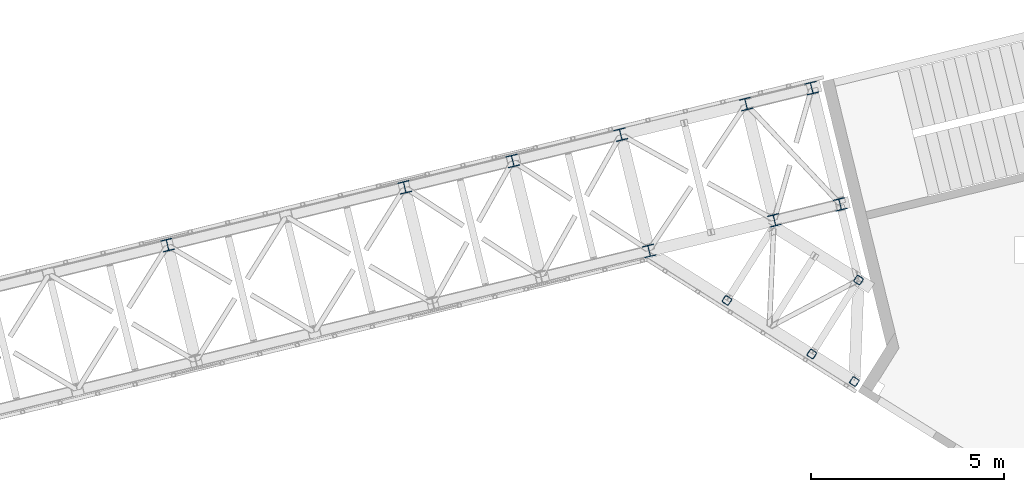
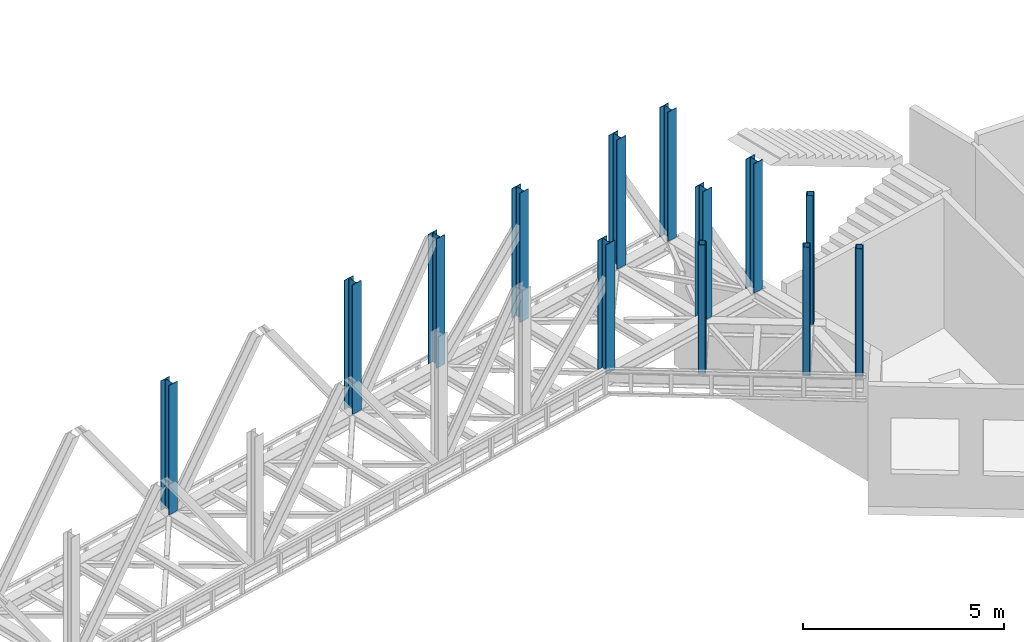
# One storey, part 3 of 92: 13 columns.
"""IFC4 building model written with IfcOpenShell, lengths in millimetres."""

from ifc_helpers import new_model, entity, si_unit, converted_unit, derived_unit, direction, frame, origin, place, context, subcontext, project, spatial, indexed_curve, outline, extrude, type_object, element, save


model = new_model("IFC4")

# Units and contexts
model_context = context("Model", 3, precision=0.01, world=origin(), true_north=direction((6.12303176911189e-17, 1.0)))
plan_context = context("Plan", 3, precision=0.01, world=origin(), true_north=direction((6.12303176911189e-17, 1.0)))
body_context = subcontext(model_context, "Body", "Model", "MODEL_VIEW")
ifc_project = project(units=[si_unit("LENGTHUNIT", "METRE", prefix="MILLI"), si_unit("AREAUNIT", "SQUARE_METRE"), si_unit("VOLUMEUNIT", "CUBIC_METRE"), converted_unit("PLANEANGLEUNIT", "DEGREE", entity("IfcRatioMeasure", 0.0174532925199433), si_unit("PLANEANGLEUNIT", "RADIAN"), dimensions=[0, 0, 0, 0, 0, 0, 0]), si_unit("MASSUNIT", "GRAM", prefix="KILO"), derived_unit("MASSDENSITYUNIT", [(si_unit("MASSUNIT", "GRAM", prefix="KILO"), 1), (si_unit("LENGTHUNIT", "METRE"), -3)]), derived_unit("MOMENTOFINERTIAUNIT", [(si_unit("LENGTHUNIT", "METRE"), 4)]), si_unit("TIMEUNIT", "SECOND"), si_unit("FREQUENCYUNIT", "HERTZ"), si_unit("THERMODYNAMICTEMPERATUREUNIT", "DEGREE_CELSIUS"), derived_unit("THERMALTRANSMITTANCEUNIT", [(si_unit("MASSUNIT", "GRAM", prefix="KILO"), 1), (si_unit("THERMODYNAMICTEMPERATUREUNIT", "KELVIN"), -1), (si_unit("TIMEUNIT", "SECOND"), -3)]), derived_unit("VOLUMETRICFLOWRATEUNIT", [(si_unit("LENGTHUNIT", "METRE"), 3), (si_unit("TIMEUNIT", "SECOND"), -1)]), derived_unit("MASSFLOWRATEUNIT", [(si_unit("MASSUNIT", "GRAM", prefix="KILO"), 1), (si_unit("TIMEUNIT", "SECOND"), -1)]), derived_unit("ROTATIONALFREQUENCYUNIT", [(si_unit("TIMEUNIT", "SECOND"), -1)]), si_unit("ELECTRICCURRENTUNIT", "AMPERE"), si_unit("ELECTRICVOLTAGEUNIT", "VOLT"), si_unit("POWERUNIT", "WATT"), si_unit("FORCEUNIT", "NEWTON", prefix="KILO"), si_unit("ILLUMINANCEUNIT", "LUX"), si_unit("LUMINOUSFLUXUNIT", "LUMEN"), si_unit("LUMINOUSINTENSITYUNIT", "CANDELA"), derived_unit("USERDEFINED", [(si_unit("MASSUNIT", "GRAM", prefix="KILO"), -1), (si_unit("LENGTHUNIT", "METRE"), -2), (si_unit("TIMEUNIT", "SECOND"), 3), (si_unit("LUMINOUSFLUXUNIT", "LUMEN"), 1)]), derived_unit("LINEARVELOCITYUNIT", [(si_unit("LENGTHUNIT", "METRE"), 1), (si_unit("TIMEUNIT", "SECOND"), -1)]), si_unit("PRESSUREUNIT", "PASCAL"), derived_unit("USERDEFINED", [(si_unit("LENGTHUNIT", "METRE"), -2), (si_unit("MASSUNIT", "GRAM", prefix="KILO"), 1), (si_unit("TIMEUNIT", "SECOND"), -2)]), derived_unit("LINEARFORCEUNIT", [(si_unit("MASSUNIT", "GRAM", prefix="KILO"), 1), (si_unit("LENGTHUNIT", "METRE"), 1), (si_unit("TIMEUNIT", "SECOND"), -2), (si_unit("LENGTHUNIT", "METRE"), -1)]), derived_unit("PLANARFORCEUNIT", [(si_unit("MASSUNIT", "GRAM", prefix="KILO"), 1), (si_unit("LENGTHUNIT", "METRE"), 1), (si_unit("TIMEUNIT", "SECOND"), -2), (si_unit("LENGTHUNIT", "METRE"), -2)])], contexts=[model_context, plan_context])

# Site, building, storey
site_placement = place(None, origin())
site = spatial("IfcSite", under=ifc_project, at=site_placement, CompositionType="ELEMENT")
building_placement = place(site_placement, origin())
building = spatial("IfcBuilding", under=site, at=building_placement, CompositionType="ELEMENT")
storey_placement = place(building_placement, frame((0.0, 0.0, 15900.0)))
storey = spatial("IfcBuildingStorey", under=building, at=storey_placement, Name="05", CompositionType="ELEMENT", Elevation=15900.0)

# Columns
column_type_1 = type_object("IfcColumnType", PredefinedType="COLUMN")
placement = place(storey_placement, origin())
element("IfcColumn", 1, at=placement, inside=storey, type_object=column_type_1, ObjectType="Steel Column", PredefinedType="COLUMN", context=body_context, shape_type="SweptSolid", body=[
    extrude(outline(indexed_curve([(-149.999999999996, -149.999999999997), (-134.499999999996, -149.999999999997), (-134.499999999997, -22.9999999999994), (-133.1298315852, -16.1116982174372), (-129.227922061356, -10.2720779386417), (-123.388301782569, -6.37016841480137), (-116.499999999997, -5.0000000000034), (116.500000000004, -5.00000000000357), (123.388301782575, -6.37016841480053), (129.22792206136, -10.272077938641), (133.129831585207, -16.1116982174367), (134.500000000004, -22.9999999999993), (134.500000000004, -149.999999999996), (150.000000000004, -149.999999999997), (150.000000000002, 150.000000000005), (134.500000000004, 150.000000000004), (134.500000000003, 22.9999999999989), (133.129831585206, 16.1116982174278), (129.22792206136, 10.2720779386507), (123.388301782574, 6.37016841479246), (116.500000000003, 4.99999999999504), (-116.499999999999, 4.99999999999782), (-123.388301782571, 6.37016841478953), (-129.22792206136, 10.2720779386521), (-133.129831585201, 16.1116982174273), (-134.500000000001, 22.9999999999972), (-134.5, 149.999999999992), (-149.999999999998, 150.000000000004), (-149.999999999996, -149.999999999997)], self_intersect=False)), frame((-5412.1, 16282.32, 3685.0), z_axis=(0.0, 0.0, 1.0), x_axis=(-0.236826092990335, 0.971552058141474, 0.0)), (0.0, 0.0, 1.0), 3931.00000000001),
])
column_type_2 = type_object("IfcColumnType", PredefinedType="COLUMN")
element("IfcColumn", 2, at=placement, inside=storey, type_object=column_type_2, ObjectType="Steel Column", PredefinedType="COLUMN", context=body_context, shape_type="SweptSolid", body=[
    extrude(outline(indexed_curve([(-149.999999999992, -150.000000000004), (-134.499999999992, -150.000000000004), (-134.499999999995, -23.0000000000064), (-133.129831585198, -16.1116982174347), (-129.227922061354, -10.2720779386484), (-123.388301782568, -6.37016841479899), (-116.499999999995, -5.00000000000143), (116.500000000005, -4.99999999999686), (123.388301782576, -6.3701684147945), (129.227922061362, -10.2720779386436), (133.129831585209, -16.1116982174297), (134.500000000006, -23.0000000000012), (134.500000000007, -149.999999999998), (150.000000000008, -149.999999999998), (150.000000000001, 150.000000000004), (134.500000000003, 150.000000000003), (134.500000000004, 23.0000000000146), (133.129831585207, 16.1116982174256), (129.227922061361, 10.2720779386482), (123.388301782575, 6.37016841479877), (116.500000000004, 5.00000000000095), (-116.499999999998, 5.00000000000006), (-123.388301782567, 6.37016841479402), (-129.227922061359, 10.2720779386449), (-133.129831585202, 16.1116982174205), (-134.5, 23.0000000000078), (-134.500000000001, 149.999999999996), (-149.999999999999, 149.999999999998), (-149.999999999992, -150.000000000004)], self_intersect=False)), frame((-2167.12, 17073.32, 3685.0), z_axis=(0.0, 0.0, 1.0), x_axis=(-0.236826092990319, 0.971552058141478, 0.0)), (0.0, 0.0, 1.0), 3931.00000000001),
])
column_type_3 = type_object("IfcColumnType", PredefinedType="COLUMN")
element("IfcColumn", 3, at=placement, inside=storey, type_object=column_type_3, ObjectType="Steel Column", PredefinedType="COLUMN", context=body_context, shape_type="SweptSolid", body=[
    extrude(outline(indexed_curve([(-150.000000000001, -150.000000000001), (-134.5, -150.000000000001), (-134.500000000002, -22.9999999999947), (-133.129831585205, -16.1116982174319), (-129.227922061361, -10.2720779386456), (-123.388301782575, -6.37016841479614), (-116.500000000002, -4.9999999999988), (116.499999999999, -4.99999999999733), (123.38830178257, -6.37016841479492), (129.227922061355, -10.272077938644), (133.129831585202, -16.1116982174302), (134.499999999999, -22.9999999999931), (134.499999999999, -149.999999999999), (149.999999999999, -149.999999999999), (149.999999999997, 150.000000000003), (134.499999999998, 150.000000000002), (134.499999999998, 23.0000000000053), (133.129831585201, 16.1116982174337), (129.227922061355, 10.272077938639), (123.388301782568, 6.37016841480707), (116.499999999998, 5.00000000000929), (-116.500000000006, 4.99999999999419), (-123.388301782583, 6.37016841479406), (-129.227922061363, 10.2720779386316), (-133.129831585209, 16.1116982174316), (-134.500000000006, 23.0000000000023), (-134.500000000006, 149.999999999999), (-150.000000000003, 150.0), (-150.000000000001, -150.000000000001)], self_intersect=False)), frame((-466.9, 17487.77, 3685.0), z_axis=(0.0, 0.0, 1.0), x_axis=(-0.236826092990331, 0.971552058141475, 0.0)), (0.0, 0.0, 1.0), 3931.00000000001),
])
column_type_4 = type_object("IfcColumnType", PredefinedType="COLUMN")
element("IfcColumn", 4, at=placement, inside=storey, type_object=column_type_4, ObjectType="Steel Column", PredefinedType="COLUMN", context=body_context, shape_type="SweptSolid", body=[
    extrude(outline(indexed_curve([(-150.000000000009, -149.999999999989), (-134.500000000008, -149.999999999989), (-134.499999999999, -22.9999999999834), (-133.129831585204, -16.1116982174208), (-129.227922061357, -10.2720779386351), (-123.38830178257, -6.37016841478617), (-116.499999999998, -4.99999999998972), (116.500000000001, -5.00000000000413), (123.388301782572, -6.37016841480157), (129.227922061359, -10.272077938653), (133.129831585204, -16.1116982174384), (134.5, -23.0000000000022), (134.499999999993, -150.000000000008), (149.999999999993, -150.000000000008), (150.000000000012, 149.999999999992), (134.500000000012, 149.999999999994), (134.500000000005, 22.9999999999887), (133.129831585207, 16.1116982174245), (129.22792206136, 10.2720779386298), (123.388301782574, 6.37016841478987), (116.500000000003, 4.9999999999929), (-116.499999999999, 5.00000000001255), (-123.388301782573, 6.3701684148084), (-129.227922061357, 10.2720779386504), (-133.129831585205, 16.111698217441), (-134.499999999997, 23.0000000000127), (-134.499999999989, 150.000000000016), (-149.999999999988, 150.000000000013), (-150.000000000009, -149.999999999989)], self_intersect=False)), frame((-17882.61, 16433.27, 3685.0), z_axis=(0.0, 0.0, 1.0), x_axis=(-0.236826092990401, 0.971552058141458, 0.0)), (0.0, 0.0, 1.0), 3931.00000000001),
])
column_type_5 = type_object("IfcColumnType", PredefinedType="COLUMN")
element("IfcColumn", 5, at=placement, inside=storey, type_object=column_type_5, ObjectType="Steel Column", PredefinedType="COLUMN", context=body_context, shape_type="SweptSolid", body=[
    extrude(outline(indexed_curve([(-149.999999999988, -150.000000000005), (-134.499999999987, -150.000000000005), (-134.499999999997, -23.0000000000148), (-133.1298315852, -16.1116982174436), (-129.227922061354, -10.2720779386484), (-123.388301782568, -6.37016841480764), (-116.499999999998, -5.00000000000974), (116.500000000003, -4.99999999999305), (123.388301782574, -6.37016841479165), (129.227922061361, -10.2720779386312), (133.129831585207, -16.111698217425), (134.500000000004, -22.9999999999976), (134.500000000012, -149.999999999985), (150.000000000012, -149.999999999985), (149.999999999993, 150.000000000017), (134.499999999992, 150.000000000015), (134.5, 23.0000000000096), (133.129831585203, 16.1116982174295), (129.22792206136, 10.2720779386426), (123.388301782574, 6.37016841480189), (116.500000000001, 5.0000000000045), (-116.500000000001, 4.9999999999815), (-123.388301782567, 6.37016841478329), (-129.227922061358, 10.2720779386192), (-133.129831585202, 16.1116982174104), (-134.5, 22.9999999999876), (-134.50000000001, 149.999999999984), (-150.00000000001, 149.999999999995), (-149.999999999988, -150.000000000005)], self_intersect=False)), frame((-11742.4, 17930.01, 3685.0), z_axis=(0.0, 0.0, 1.0), x_axis=(-0.236826092990269, 0.97155205814149, 0.0)), (0.0, 0.0, 1.0), 3931.00000000001),
])
column_type_6 = type_object("IfcColumnType", PredefinedType="COLUMN")
element("IfcColumn", 6, at=placement, inside=storey, type_object=column_type_6, ObjectType="Steel Column", PredefinedType="COLUMN", context=body_context, shape_type="SweptSolid", body=[
    extrude(outline(indexed_curve([(-149.999999999995, -150.000000000002), (-134.499999999995, -150.000000000002), (-134.499999999996, -22.9999999999962), (-133.129831585199, -16.111698217433), (-129.227922061352, -10.272077938647), (-123.388301782566, -6.37016841479767), (-116.499999999996, -5.00000000000024), (116.500000000005, -4.99999999999936), (123.388301782576, -6.37016841479738), (129.227922061364, -10.2720779386463), (133.129831585208, -16.1116982174325), (134.500000000006, -22.9999999999951), (134.500000000004, -150.000000000001), (150.000000000005, -150.0), (150.000000000006, 150.0), (134.500000000003, 150.0), (134.500000000004, 22.9999999999942), (133.129831585207, 16.111698217432), (129.227922061363, 10.2720779386365), (123.388301782577, 6.37016841480404), (116.500000000004, 5.00000000000712), (-116.499999999998, 4.9999999999931), (-123.388301782573, 6.37016841479215), (-129.227922061356, 10.2720779386311), (-133.129831585202, 16.1116982174309), (-134.499999999995, 22.9999999999915), (-134.499999999997, 149.999999999996), (-149.999999999996, 149.999999999999), (-149.999999999995, -150.000000000002)], self_intersect=False)), frame((-8944.33, 18612.07, 3685.0), z_axis=(0.0, 0.0, 1.0), x_axis=(-0.236826092990335, 0.971552058141474, 0.0)), (0.0, 0.0, 1.0), 3931.00000000001),
])
column_type_7 = type_object("IfcColumnType", PredefinedType="COLUMN")
element("IfcColumn", 7, at=placement, inside=storey, type_object=column_type_7, ObjectType="Steel Column", PredefinedType="COLUMN", context=body_context, shape_type="SweptSolid", body=[
    extrude(outline(indexed_curve([(-149.999999999997, -150.000000000001), (-134.499999999997, -150.000000000001), (-134.499999999998, -23.0000000000036), (-133.129831585201, -16.1116982174325), (-129.227922061355, -10.2720779386464), (-123.388301782568, -6.37016841479716), (-116.499999999998, -4.99999999999867), (116.500000000003, -4.99999999999885), (123.388301782574, -6.37016841479581), (129.227922061361, -10.2720779386458), (133.129831585206, -16.111698217432), (134.500000000003, -23.0000000000035), (134.500000000003, -150.0), (150.000000000003, -150.0), (150.000000000004, 150.000000000001), (134.500000000003, 150.000000000001), (134.500000000002, 23.0000000000125), (133.129831585205, 16.1116982174236), (129.227922061361, 10.272077938646), (123.388301782575, 6.37016841479667), (116.500000000002, 4.9999999999987), (-116.499999999995, 5.00000000000257), (-123.388301782567, 6.37016841479638), (-129.227922061361, 10.2720779386489), (-133.129831585202, 16.1116982174241), (-134.5, 23.0000000000104), (-134.499999999999, 149.999999999998), (-149.999999999999, 150.0), (-149.999999999997, -150.000000000001)], self_intersect=False)), frame((-6146.26, 19294.13, 3685.0), z_axis=(0.0, 0.0, 1.0), x_axis=(-0.236826092990335, 0.971552058141474, 0.0)), (0.0, 0.0, 1.0), 3931.00000000001),
])
column_type_8 = type_object("IfcColumnType", PredefinedType="COLUMN")
element("IfcColumn", 8, at=placement, inside=storey, type_object=column_type_8, ObjectType="Steel Column", PredefinedType="COLUMN", context=body_context, shape_type="SweptSolid", body=[
    extrude(outline(indexed_curve([(-150.000000000002, -150.000000000001), (-134.500000000001, -150.000000000001), (-134.500000000002, -23.0000000000041), (-133.129831585203, -16.1116982174241), (-129.227922061361, -10.272077938646), (-123.388301782573, -6.37016841478825), (-116.500000000002, -4.99999999999082), (116.499999999998, -4.99999999999048), (123.388301782569, -6.37016841478797), (129.227922061355, -10.2720779386453), (133.129831585202, -16.1116982174231), (134.499999999997, -23.000000000003), (134.499999999998, -150.0), (149.999999999998, -150.0), (149.999999999997, 150.000000000001), (134.499999999997, 150.000000000001), (134.499999999998, 23.0000000000036), (133.129831585203, 16.111698217423), (129.227922061355, 10.2720779386375), (123.388301782568, 6.37016841480555), (116.499999999998, 5.0000000000076), (-116.500000000004, 5.00000000000199), (-123.388301782586, 6.37016841479418), (-129.227922061352, 10.27207793864), (-133.129831585206, 16.1116982174225), (-134.500000000006, 23.0000000000014), (-134.500000000007, 149.999999999999), (-150.000000000003, 150.0), (-150.000000000002, -150.000000000001)], self_intersect=False)), frame((-2901.28, 20085.13, 3685.0), z_axis=(0.0, 0.0, 1.0), x_axis=(-0.236826092990335, 0.971552058141474, 0.0)), (0.0, 0.0, 1.0), 3931.00000000001),
])
column_type_9 = type_object("IfcColumnType", PredefinedType="COLUMN")
element("IfcColumn", 9, at=placement, inside=storey, type_object=column_type_9, ObjectType="Steel Column", PredefinedType="COLUMN", context=body_context, shape_type="SweptSolid", body=[
    extrude(outline(indexed_curve([(-150.000000000001, -149.999999999998), (-134.500000000001, -149.999999999998), (-134.499999999997, -23.0000000000021), (-133.1298315852, -16.1116982174305), (-129.227922061356, -10.2720779386442), (-123.38830178257, -6.37016841479494), (-116.499999999997, -5.00000000000616), (116.499999999999, -5.00000000000491), (123.388301782572, -6.37016841479425), (129.22792206136, -10.2720779386437), (133.129831585205, -16.1116982174296), (134.500000000002, -23.0000000000013), (134.500000000003, -149.999999999999), (150.000000000003, -149.999999999998), (150.000000000002, 150.000000000003), (134.500000000002, 150.000000000003), (134.500000000001, 22.999999999997), (133.129831585204, 16.1116982174257), (129.227922061361, 10.2720779386475), (123.388301782571, 6.37016841479901), (116.5, 5.00000000000105), (-116.500000000002, 4.99999999999571), (-123.388301782567, 6.37016841479756), (-129.227922061365, 10.2720779386414), (-133.129831585201, 16.1116982174245), (-134.499999999999, 22.9999999999942), (-134.500000000002, 150.000000000001), (-149.999999999998, 150.000000000002), (-150.000000000001, -149.999999999998)], self_intersect=False)), frame((-1201.06, 20499.58, 3685.0), z_axis=(0.0, 0.0, 1.0), x_axis=(-0.236826092990335, 0.971552058141474, 0.0)), (0.0, 0.0, 1.0), 3931.00000000001),
])
column_type_10 = type_object("IfcColumnType", PredefinedType="COLUMN")
element("IfcColumn", 10, at=placement, inside=storey, type_object=column_type_10, ObjectType="Steel Column", PredefinedType="COLUMN", context=body_context, shape_type="SweptSolid", body=[
    extrude(outline(indexed_curve([(49.1459374271497, -111.734850581474), (60.8513567481022, -111.734850581474), (71.6657540781827, -107.255380538444), (79.9427354566247, -98.9783991599474), (84.4222054995761, -88.164001829847), (111.73485058112, 49.1459374266677), (111.734850581068, 60.8513567476448), (107.255380537993, 71.6657540777505), (98.9783991594631, 79.9427354562349), (88.164001829344, 84.422205499254), (-49.1459374271436, 111.734850581483), (-60.8513567481105, 111.734850581473), (-71.6657540781771, 107.255380538453), (-79.9427354566186, 98.9783991599569), (-84.4222054995844, 88.164001829846), (-111.734850581129, -49.1459374266687), (-111.734850581063, -60.8513567476355), (-107.255380537988, -71.6657540777412), (-98.9783991594714, -79.9427354562359), (-88.1640018293524, -84.422205499255), (49.1459374271497, -111.734850581474)], self_intersect=False), holes=[indexed_curve([(-76.4052458051974, -76.5652559153672), (-87.2196431353149, -72.0857858723521), (-95.4966245138426, -63.8088044938667), (-99.9760945569088, -52.9944071637622), (-99.9760945569793, -41.2889878427855), (-76.5652559156544, 76.4052458056415), (-72.0857858726852, 87.2196431357655), (-63.8088044942536, 95.4966245142528), (-52.9944071641797, 99.9760945572851), (-41.2889878432147, 99.9760945572831), (76.4052458052092, 76.5652559153813), (87.2196431353298, 72.0857858723628), (95.4966245138503, 63.8088044938722), (99.9760945569322, 52.9944071637623), (99.9760945569808, 41.2889878427978), (76.565255915663, -76.4052458056497), (72.0857858727068, -87.2196431357497), (63.8088044942605, -95.4966245142454), (52.9944071641819, -99.9760945572702), (41.2889878432301, -99.9760945572722), (-76.4052458051974, -76.5652559153672)], self_intersect=False)]), frame((-3398.02, 15001.72, 3704.05), z_axis=(0.0, 0.0, 1.0), x_axis=(0.927336857834339, -0.374227674152961, 0.0)), (0.0, 0.0, 1.0), 3911.94999999865),
])
column_type_11 = type_object("IfcColumnType", PredefinedType="COLUMN")
element("IfcColumn", 11, at=placement, inside=storey, type_object=column_type_11, ObjectType="Steel Column", PredefinedType="COLUMN", context=body_context, shape_type="SweptSolid", body=[
    extrude(outline(indexed_curve([(49.1459374271164, -111.734850581488), (60.8513567480769, -111.734850581488), (71.6657540781519, -107.255380538466), (79.9427354565958, -98.9783991599725), (84.4222054995496, -88.1640018298711), (111.734850581139, 49.1459374266412), (111.734850581084, 60.8513567476111), (107.255380538012, 71.6657540777182), (98.978399159483, 79.9427354562066), (88.1640018293653, 84.4222054992288), (-49.145937427114, 111.734850581494), (-60.8513567480805, 111.734850581487), (-71.6657540781486, 107.25538053847), (-79.9427354565935, 98.9783991599781), (-84.422205499554, 88.1640018298717), (-111.734850581143, -49.1459374266407), (-111.734850581081, -60.8513567476055), (-107.255380538016, -71.6657540777197), (-98.9783991594876, -79.9427354562061), (-88.1640018293708, -84.4222054992264), (49.1459374271164, -111.734850581488)], self_intersect=False), holes=[indexed_curve([(-76.4052458052286, -76.5652559153525), (-87.2196431353317, -72.0857858723221), (-95.4966245138585, -63.8088044938397), (-99.9760945569253, -52.994407163726), (-99.9760945569795, -41.2889878427604), (-76.565255915633, 76.4052458056721), (-72.0857858726692, 87.2196431357797), (-63.8088044942326, 95.4966245142753), (-52.9944071641458, 99.9760945572999), (-41.2889878431907, 99.9760945573), (76.4052458052273, 76.5652559153613), (87.2196431353477, 72.0857858723379), (95.4966245138657, 63.8088044938449), (99.9760945569434, 52.9944071637356), (99.9760945569909, 41.2889878427674), (76.5652559156335, -76.4052458056765), (72.08578587268, -87.2196431357707), (63.8088044942338, -95.4966245142678), (52.9944071641561, -99.9760945572911), (41.2889878432009, -99.9760945572913), (-76.4052458052286, -76.5652559153525)], self_intersect=False)]), frame((-1200.35, 13612.37, 3704.05), z_axis=(0.0, 0.0, 1.0), x_axis=(0.927336857834443, -0.374227674152704, 0.0)), (0.0, 0.0, 1.0), 3911.94999999865),
])
column_type_12 = type_object("IfcColumnType", PredefinedType="COLUMN")
element("IfcColumn", 12, at=placement, inside=storey, type_object=column_type_12, ObjectType="Steel Column", PredefinedType="COLUMN", context=body_context, shape_type="SweptSolid", body=[
    extrude(outline(indexed_curve([(49.1459374271479, -111.734850581477), (60.8513567481005, -111.734850581477), (71.6657540781822, -107.255380538449), (79.942735456624, -98.9783991599525), (84.4222054995816, -88.1640018298449), (111.73485058112, 49.1459374266626), (111.734850581068, 60.8513567476397), (107.255380537992, 71.6657540777475), (98.9783991594696, 79.9427354562349), (88.1640018293507, 84.4222054992541), (-49.1459374271442, 111.734850581479), (-60.8513567481046, 111.734850581475), (-71.6657540781775, 107.255380538448), (-79.9427354566199, 98.9783991599542), (-84.4222054995847, 88.1640018298413), (-111.734850581122, -49.1459374266682), (-111.734850581063, -60.8513567476401), (-107.255380537988, -71.6657540777459), (-98.9783991594718, -79.9427354562404), (-88.1640018293538, -84.4222054992577), (49.1459374271479, -111.734850581477)], self_intersect=False), holes=[indexed_curve([(-76.405245805199, -76.5652559153723), (-87.2196431353247, -72.0857858723581), (-95.4966245138401, -63.8088044938678), (-99.9760945569111, -52.9944071637605), (-99.9760945569715, -41.2889878427845), (-76.5652559156569, 76.4052458056406), (-72.0857858727002, 87.2196431357549), (-63.8088044942489, 95.4966245142572), (-52.9944071641895, 99.9760945572789), (-41.288987843225, 99.976094557279), (76.405245805199, 76.5652559153769), (87.2196431353195, 72.0857858723584), (95.4966245138483, 63.8088044938711), (99.9760945569213, 52.9944071637623), (99.9760945569802, 41.2889878427926), (76.5652559156549, -76.4052458056438), (72.0857858726969, -87.2196431357562), (63.8088044942512, -95.4966245142516), (52.9944071641729, -99.9760945572739), (41.2889878432206, -99.9760945572808), (-76.405245805199, -76.5652559153723)], self_intersect=False)]), frame((-97.51, 12899.19, 3704.05), z_axis=(0.0, 0.0, 1.0), x_axis=(0.92733685783434, -0.37422767415296, 0.0)), (0.0, 0.0, 1.0), 3911.94999999863),
])
column_type_13 = type_object("IfcColumnType", PredefinedType="COLUMN")
element("IfcColumn", 13, at=placement, inside=storey, type_object=column_type_13, ObjectType="Steel Column", PredefinedType="COLUMN", context=body_context, shape_type="SweptSolid", body=[
    extrude(outline(indexed_curve([(49.1459374271653, -111.734850581469), (60.8513567481188, -111.734850581469), (71.6657540781987, -107.255380538437), (79.9427354566391, -98.9783991599396), (84.4222054995957, -88.1640018298332), (111.73485058111, 49.145937426681), (111.734850581056, 60.851356747658), (107.255380537979, 71.6657540777631), (98.9783991594545, 79.9427354562511), (88.164001829335, 84.4222054992685), (-49.1459374271645, 111.73485058147), (-60.8513567481242, 111.734850581462), (-71.6657540781971, 107.255380538435), (-79.9427354566384, 98.9783991599399), (-84.422205499601, 88.1640018298264), (-111.734850581115, -49.1459374266878), (-111.734850581054, -60.8513567476597), (-107.255380537978, -71.6657540777648), (-98.9783991594459, -79.9427354562476), (-88.1640018293263, -84.422205499265), (49.1459374271653, -111.734850581469)], self_intersect=False), holes=[indexed_curve([(-76.4052458051801, -76.5652559153829), (-87.2196431353051, -72.0857858723723), (-95.4966245138212, -63.8088044938761), (-99.9760945568963, -52.9944071637752), (-99.9760945569587, -41.2889878427991), (-76.5652559156719, 76.4052458056267), (-72.0857858727091, 87.219643135745), (-63.8088044942591, 95.4966245142487), (-52.9944071641943, 99.9760945572747), (-41.2889878432332, 99.9760945572872), (76.4052458051925, 76.5652559153902), (87.2196431353133, 72.0857858723756), (95.4966245138369, 63.8088044938824), (99.9760945569188, 52.9944071637795), (99.9760945569709, 41.2889878428087), (76.5652559156743, -76.4052458056305), (72.0857858727174, -87.2196431357416), (63.808804494274, -95.4966245142404), (52.9944071642026, -99.9760945572621), (41.2889878432433, -99.9760945572714), (-76.4052458051801, -76.5652559153829)], self_intersect=False)]), frame((10.78, 15528.14, 3685.0), z_axis=(0.0, 0.0, 1.0), x_axis=(0.927336857834276, -0.374227674153116, 0.0)), (0.0, 0.0, 1.0), 3911.94999999863),
])

save(model, "model.ifc")
